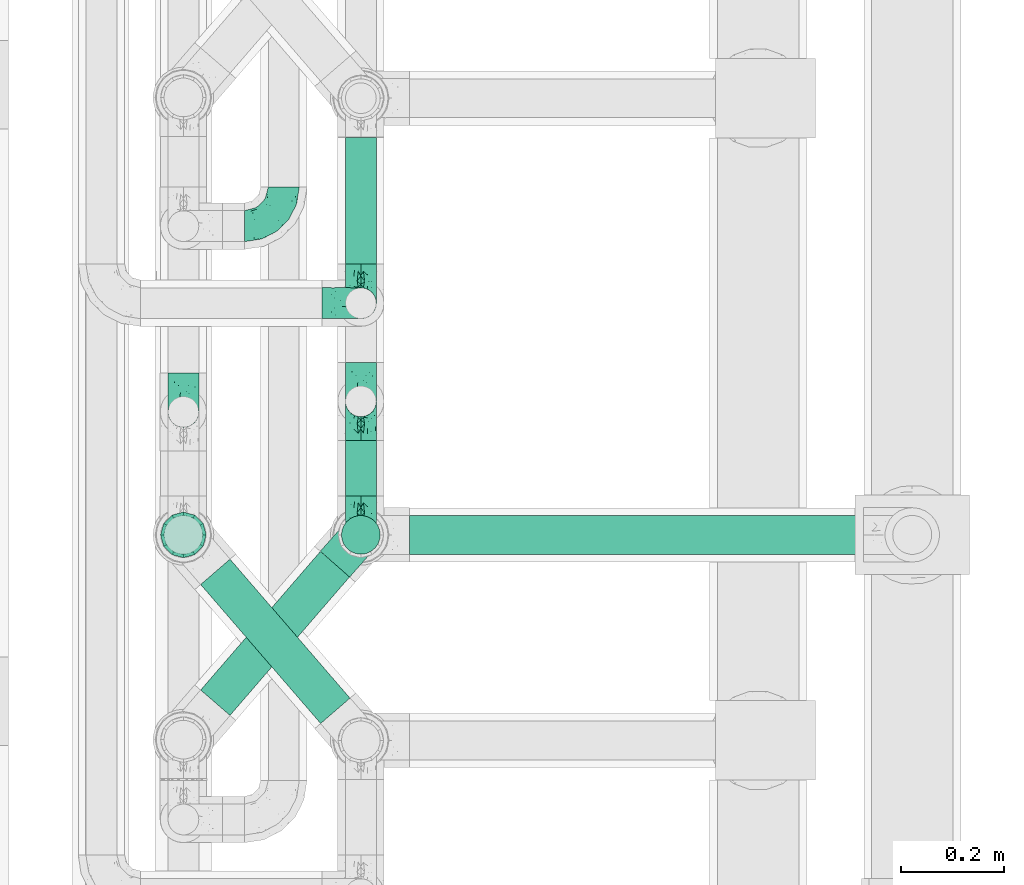
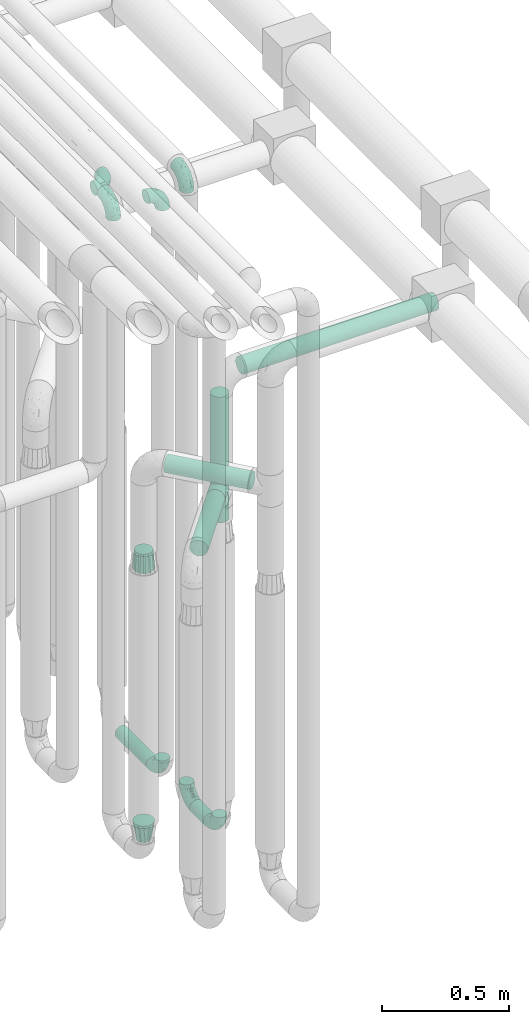
# One storey, part 613 of 827: 10 flow fittings, 7 flow segments.
"""IFC2X3 building model written with IfcOpenShell, lengths in millimetres."""

import ifcopenshell
import ifcopenshell.guid

model = None  # the IFC model being written
_history = None  # IfcOwnerHistory: only IFC2X3 demands one
_inside = {}  # id of a spatial element -> (the spatial element, [elements in it])
_under = {}  # id of a project, library or spatial element -> (it, [spatial elements below it])
_declared = {}  # id of a project -> (the project, [libraries it declares])
_typed = {}  # id of a type object -> (the type object, [elements of that type])
_made_of = {}  # id of a material, layer set ... -> (it, [elements and type objects made of it])


def new_model(schema):
    """Start an empty IFC model of exactly this schema.

    Asked for "IFC4X3", IfcOpenShell would pick the latest addendum, in which some entities
    have other attributes; the version numbers below select the first issue.
    IFC2X3 requires an IfcOwnerHistory on every rooted entity: one is made here for all.
    """
    global model, _history
    if schema == "IFC4X3":
        model = ifcopenshell.file(schema_version=(4, 3, 0, 0))
    else:
        model = ifcopenshell.file(schema=schema)
    _inside.clear()
    _under.clear()
    _declared.clear()
    _typed.clear()
    _made_of.clear()
    _history = None
    if model.schema == "IFC2X3":
        org = make("IfcOrganization", Name="unknown")
        user = make(
            "IfcPersonAndOrganization",
            ThePerson=make("IfcPerson", FamilyName="unknown"),
            TheOrganization=org,
        )
        app = make(
            "IfcApplication",
            ApplicationDeveloper=org,
            Version="unknown",
            ApplicationFullName="unknown",
            ApplicationIdentifier="unknown",
        )
        _history = make(
            "IfcOwnerHistory",
            OwningUser=user,
            OwningApplication=app,
            ChangeAction="ADDED",
            CreationDate=0,
        )
    return model


def make(cls, **values):
    """One entity of the class cls with the attributes given. An attribute that is None is left unset."""
    return model.create_entity(
        cls, **{name: value for name, value in values.items() if value is not None}
    )


def entity(cls, *values):
    """Any entity or typed value of the class cls, its attributes in the order of the schema. None: left unset."""
    e = model.create_entity(cls)
    for i, value in enumerate(values):
        if value is not None:
            e[i] = value
    return e


def rooted(cls, **values):
    """An entity with a GlobalId (a new one), such as an element, a storey or a relation."""
    return make(cls, GlobalId=ifcopenshell.guid.new(), OwnerHistory=_history, **values)


def si_unit(unit_type, name, prefix=None):
    """IfcSIUnit, for example si_unit("LENGTHUNIT", "METRE", prefix="MILLI")."""
    return make("IfcSIUnit", UnitType=unit_type, Prefix=prefix, Name=name)


def converted_unit(unit_type, name, factor, base, dimensions=None, offset=None):
    """IfcConversionBasedUnit, such as the inch: factor (a typed value) times the base unit."""
    return make(
        "IfcConversionBasedUnit"
        if offset is None
        else "IfcConversionBasedUnitWithOffset",
        ConversionOffset=offset,
        Dimensions=None
        if dimensions is None
        else entity("IfcDimensionalExponents", *dimensions),
        UnitType=unit_type,
        Name=name,
        ConversionFactor=make(
            "IfcMeasureWithUnit", ValueComponent=factor, UnitComponent=base
        ),
    )


def derived_unit(unit_type, elements):
    """IfcDerivedUnit: a product of units, each with its exponent."""
    return make(
        "IfcDerivedUnit",
        Elements=[
            make("IfcDerivedUnitElement", Unit=unit, Exponent=power)
            for unit, power in elements
        ],
        UnitType=unit_type,
    )


def assignment(units):
    """IfcUnitAssignment: the units of a project."""
    return None if units is None else make("IfcUnitAssignment", Units=units)


def point(xyz):
    """IfcCartesianPoint."""
    return None if xyz is None else make("IfcCartesianPoint", Coordinates=xyz)


def direction(xyz):
    """IfcDirection."""
    return None if xyz is None else make("IfcDirection", DirectionRatios=xyz)


def frame(location, z_axis=None, x_axis=None):
    """IfcAxis2Placement3D, a coordinate frame: its origin and axes. An axis left out is left unset."""
    return make(
        "IfcAxis2Placement3D",
        Location=point(location),
        Axis=direction(z_axis),
        RefDirection=direction(x_axis),
    )


def frame_2d(location, x_axis=None):
    """IfcAxis2Placement2D, a coordinate frame in the plane: its origin and x axis."""
    return make(
        "IfcAxis2Placement2D", Location=point(location), RefDirection=direction(x_axis)
    )


def origin():
    """The frame at (0, 0, 0) with its axes left unset."""
    return frame((0.0, 0.0, 0.0))


def origin_2d_with_axis():
    """The frame at (0, 0) in the plane with the x axis (1, 0) written out."""
    return frame_2d((0.0, 0.0), x_axis=(1.0, 0.0))


def place(relative_to, where):
    """IfcLocalPlacement: puts the frame where relative to a parent placement (None: the world)."""
    return make(
        "IfcLocalPlacement", PlacementRelTo=relative_to, RelativePlacement=where
    )


def context(
    kind, dimensions, precision=None, world=None, true_north=None, identifier=None
):
    """IfcGeometricRepresentationContext, for example the 3D "Model" context."""
    return make(
        "IfcGeometricRepresentationContext",
        ContextIdentifier=identifier,
        ContextType=kind,
        CoordinateSpaceDimension=dimensions,
        Precision=precision,
        WorldCoordinateSystem=world,
        TrueNorth=true_north,
    )


def subcontext(parent, identifier, kind, view, scale=None):
    """IfcGeometricRepresentationSubContext, for example "Body" below "Model"."""
    return make(
        "IfcGeometricRepresentationSubContext",
        ContextIdentifier=identifier,
        ContextType=kind,
        ParentContext=parent,
        TargetScale=scale,
        TargetView=view,
    )


def project(units=None, contexts=None):
    """IfcProject with its units and contexts."""
    return rooted(
        "IfcProject",
        Name="project",
        RepresentationContexts=contexts,
        UnitsInContext=assignment(units),
    )


def spatial(cls, under=None, at=None, **own):
    """A site, building, storey or space (cls), placed at a placement, below another one or the project."""
    s = rooted(cls, ObjectPlacement=at, **own)
    if under is not None:
        _under.setdefault(under.id(), (under, []))[1].append(s)
    return s


def profile(cls, at=None, kind="AREA", **sizes):
    """A parametric profile (cls). Its sizes go by their IFC names, for example OverallWidth=200.0."""
    return make(cls, ProfileType=kind, Position=at, **sizes)


def circle(**sizes):
    """IfcCircleProfileDef."""
    return profile("IfcCircleProfileDef", **sizes)


def extrude(swept, where, along, depth):
    """IfcExtrudedAreaSolid: the profile swept, set in the frame where, extruded along a direction by depth."""
    return make(
        "IfcExtrudedAreaSolid",
        SweptArea=swept,
        Position=where,
        ExtrudedDirection=direction(along),
        Depth=depth,
    )


def faces_of(points, faces, orient=None, outer=None):
    """IfcFace entities. A face is a list of loops; a loop is a list of indices into points, from 0.

    orient and outer hold one flag for each loop. By default every Orientation is true, the
    first loop of a face is its IfcFaceOuterBound and the others are IfcFaceBound.
    """
    made = []
    for i, loops in enumerate(faces):
        bounds = []
        for j, loop in enumerate(loops):
            is_outer = j == 0 if outer is None else outer[i][j]
            bounds.append(
                make(
                    "IfcFaceOuterBound" if is_outer else "IfcFaceBound",
                    Bound=make("IfcPolyLoop", Polygon=[points[k] for k in loop]),
                    Orientation=True if orient is None else orient[i][j],
                )
            )
        made.append(make("IfcFace", Bounds=bounds))
    return made


def faceted_brep(points, faces, orient=None, outer=None, voids=None):
    """IfcFacetedBrep: a solid bounded by flat faces; with voids (closed shells), ...WithVoids."""
    shared = [point(p) for p in points]
    hull = make("IfcClosedShell", CfsFaces=faces_of(shared, faces, orient, outer))
    if voids is None:
        return make("IfcFacetedBrep", Outer=hull)
    return make(
        "IfcFacetedBrepWithVoids",
        Outer=hull,
        Voids=[
            make(cls, CfsFaces=faces_of(shared, fs, o, b)) for cls, fs, o, b in voids
        ],
    )


def shape(context_of_items, identifier, shape_type, items):
    """IfcShapeRepresentation: the items that make up one representation, for example the "Body"."""
    return make(
        "IfcShapeRepresentation",
        ContextOfItems=context_of_items,
        RepresentationIdentifier=identifier,
        RepresentationType=shape_type,
        Items=items,
    )


def source(mapping_origin, context_of_items, identifier, shape_type, items):
    """IfcRepresentationMap: a shape defined once, which mapped items show again and again."""
    return make(
        "IfcRepresentationMap",
        MappingOrigin=mapping_origin,
        MappedRepresentation=shape(context_of_items, identifier, shape_type, items),
    )


def transform(
    local_origin,
    x_axis=None,
    y_axis=None,
    z_axis=None,
    scale=None,
    scale2=None,
    scale3=None,
    uniform=True,
):
    """IfcCartesianTransformationOperator3D, or its non-uniform kind. x_axis, y_axis, z_axis: its Axis1, 2, 3."""
    if uniform:
        return make(
            "IfcCartesianTransformationOperator3D",
            Axis1=direction(x_axis),
            Axis2=direction(y_axis),
            LocalOrigin=point(local_origin),
            Scale=scale,
            Axis3=direction(z_axis),
        )
    return make(
        "IfcCartesianTransformationOperator3DnonUniform",
        Axis1=direction(x_axis),
        Axis2=direction(y_axis),
        LocalOrigin=point(local_origin),
        Scale=scale,
        Axis3=direction(z_axis),
        Scale2=scale2,
        Scale3=scale3,
    )


def mapped(mapping_source, mapping_target):
    """IfcMappedItem: shows the shape of a source again, moved by a transform."""
    return make(
        "IfcMappedItem", MappingSource=mapping_source, MappingTarget=mapping_target
    )


def material(Name=None, Category=None):
    """IfcMaterial."""
    return make("IfcMaterial", Name=Name, Category=Category)


def made_of(thing, what):
    """Note that an element or type object is made of a material, layer set ...; save() writes the relation."""
    if what is not None:
        _made_of.setdefault(what.id(), (what, []))[1].append(thing)
    return thing


def type_object(cls, material=None, **own):
    """A type object (cls), such as IfcWallType, which elements share."""
    return made_of(rooted(cls, **own), material)


def type_shapes(of_type, sources):
    """Give a type object the sources (RepresentationMaps) that its elements show as mapped items."""
    of_type.RepresentationMaps = sources


def element(
    cls,
    number,
    at=None,
    inside=None,
    cuts=None,
    type_object=None,
    material=None,
    context=None,
    identifier="Body",
    shape_type=None,
    held_by="IfcProductDefinitionShape",
    body=None,
    shapes=None,
    **own,
):
    """One element of the class cls, such as IfcWall. Its Tag is "e" and its number.

    at: its placement. inside: the storey or other place that contains it. cuts: it is an
    opening in that element (IfcRelVoidsElement). A single representation is given by context,
    identifier, shape_type and body (its items); several are given by shapes. held_by: the class
    of the entity that holds the representations. save() writes the other relations.
    """
    e = rooted(cls, Tag="e%d" % number, ObjectPlacement=at, **own)
    if body is not None:
        shapes = [shape(context, identifier, shape_type, body)]
    if shapes is not None:
        e.Representation = make(held_by, Representations=shapes)
    if inside is not None:
        _inside.setdefault(inside.id(), (inside, []))[1].append(e)
    if cuts is not None:
        rooted(
            "IfcRelVoidsElement", RelatingBuildingElement=cuts, RelatedOpeningElement=e
        )
    if type_object is not None:
        _typed.setdefault(type_object.id(), (type_object, []))[1].append(e)
    return made_of(e, material)


def aggregate(whole, parts):
    """IfcRelAggregates: a whole, such as a stair, and the parts it consists of."""
    return rooted("IfcRelAggregates", RelatingObject=whole, RelatedObjects=parts)


def save(model, path):
    """Write the relations noted so far, then the file.

    IfcRelAggregates (storeys below a building ...), IfcRelContainedInSpatialStructure (elements
    in a storey), IfcRelDefinesByType, IfcRelAssociatesMaterial and IfcRelDeclares: one each for
    every whole, place, type object, material and project.
    """
    for whole, parts in _under.values():
        aggregate(whole, parts)
    for where, things in _inside.values():
        rooted(
            "IfcRelContainedInSpatialStructure",
            RelatedElements=things,
            RelatingStructure=where,
        )
    for kind, things in _typed.values():
        rooted("IfcRelDefinesByType", RelatedObjects=things, RelatingType=kind)
    for what, things in _made_of.values():
        rooted("IfcRelAssociatesMaterial", RelatedObjects=things, RelatingMaterial=what)
    for by, libraries in _declared.values():
        rooted("IfcRelDeclares", RelatingContext=by, RelatedDefinitions=libraries)
    model.write(path)


model = new_model("IFC2X3")

# Units and contexts
model_context = context("Model", 3, precision=0.01, world=origin(), true_north=direction((6.12303176911189e-17, 1.0)))
body_context = subcontext(model_context, "Body", "Model", "MODEL_VIEW")
ifc_project = project(units=[si_unit("LENGTHUNIT", "METRE", prefix="MILLI"), si_unit("AREAUNIT", "SQUARE_METRE"), si_unit("VOLUMEUNIT", "CUBIC_METRE"), converted_unit("PLANEANGLEUNIT", "DEGREE", entity("IfcRatioMeasure", 0.0174532925199433), si_unit("PLANEANGLEUNIT", "RADIAN"), dimensions=[0, 0, 0, 0, 0, 0, 0]), si_unit("MASSUNIT", "GRAM", prefix="KILO"), derived_unit("MASSDENSITYUNIT", [(si_unit("MASSUNIT", "GRAM", prefix="KILO"), 1), (si_unit("LENGTHUNIT", "METRE"), -3)]), derived_unit("MOMENTOFINERTIAUNIT", [(si_unit("LENGTHUNIT", "METRE"), 4)]), si_unit("TIMEUNIT", "SECOND"), si_unit("FREQUENCYUNIT", "HERTZ"), si_unit("THERMODYNAMICTEMPERATUREUNIT", "DEGREE_CELSIUS"), derived_unit("THERMALTRANSMITTANCEUNIT", [(si_unit("MASSUNIT", "GRAM", prefix="KILO"), 1), (si_unit("THERMODYNAMICTEMPERATUREUNIT", "KELVIN"), -1), (si_unit("TIMEUNIT", "SECOND"), -3)]), derived_unit("VOLUMETRICFLOWRATEUNIT", [(si_unit("LENGTHUNIT", "METRE"), 3), (si_unit("TIMEUNIT", "SECOND"), -1)]), derived_unit("MASSFLOWRATEUNIT", [(si_unit("MASSUNIT", "GRAM", prefix="KILO"), 1), (si_unit("TIMEUNIT", "SECOND"), -1)]), derived_unit("ROTATIONALFREQUENCYUNIT", [(si_unit("TIMEUNIT", "SECOND"), -1)]), si_unit("ELECTRICCURRENTUNIT", "AMPERE"), si_unit("ELECTRICVOLTAGEUNIT", "VOLT"), si_unit("POWERUNIT", "WATT"), si_unit("FORCEUNIT", "NEWTON", prefix="KILO"), si_unit("ILLUMINANCEUNIT", "LUX"), si_unit("LUMINOUSFLUXUNIT", "LUMEN"), si_unit("LUMINOUSINTENSITYUNIT", "CANDELA"), derived_unit("USERDEFINED", [(si_unit("MASSUNIT", "GRAM", prefix="KILO"), -1), (si_unit("LENGTHUNIT", "METRE"), -2), (si_unit("TIMEUNIT", "SECOND"), 3), (si_unit("LUMINOUSFLUXUNIT", "LUMEN"), 1)]), derived_unit("LINEARVELOCITYUNIT", [(si_unit("LENGTHUNIT", "METRE"), 1), (si_unit("TIMEUNIT", "SECOND"), -1)]), si_unit("PRESSUREUNIT", "PASCAL"), derived_unit("USERDEFINED", [(si_unit("LENGTHUNIT", "METRE"), -2), (si_unit("MASSUNIT", "GRAM", prefix="KILO"), 1), (si_unit("TIMEUNIT", "SECOND"), -2)]), derived_unit("LINEARFORCEUNIT", [(si_unit("MASSUNIT", "GRAM", prefix="KILO"), 1), (si_unit("LENGTHUNIT", "METRE"), 1), (si_unit("TIMEUNIT", "SECOND"), -2), (si_unit("LENGTHUNIT", "METRE"), -1)]), derived_unit("PLANARFORCEUNIT", [(si_unit("MASSUNIT", "GRAM", prefix="KILO"), 1), (si_unit("LENGTHUNIT", "METRE"), 1), (si_unit("TIMEUNIT", "SECOND"), -2), (si_unit("LENGTHUNIT", "METRE"), -2)])], contexts=[model_context])

# Site, building, storey
site_placement = place(None, origin())
site = spatial("IfcSite", under=ifc_project, at=site_placement, CompositionType="ELEMENT")
building_placement = place(site_placement, origin())
building = spatial("IfcBuilding", under=site, at=building_placement, CompositionType="ELEMENT")
storey_placement = place(building_placement, frame((0.0, 0.0, 28200.0)))
storey = spatial("IfcBuildingStorey", under=building, at=storey_placement, Name="08", CompositionType="ELEMENT", Elevation=28200.0)

# Flow segments
pipe_segment_type = type_object("IfcPipeSegmentType", PredefinedType="NOTDEFINED")
flow_segment_1_placement = place(storey_placement, frame((36943.44, 11007.17, 368.4)))
element("IfcFlowSegment", 1, at=flow_segment_1_placement, inside=storey, type_object=pipe_segment_type, context=body_context, shape_type="SweptSolid", body=[
    extrude(circle(Radius=30.0, at=origin_2d_with_axis()), frame((31.6, 0.0, 31.6), z_axis=(0.0, 1.0, 0.0), x_axis=(1.0, 0.0, 0.0)), (0.0, 0.0, 1.0), 247.028730184572),
])
flow_segment_2_placement = place(storey_placement, frame((36943.44, 10556.2, 368.4)))
element("IfcFlowSegment", 2, at=flow_segment_2_placement, inside=storey, type_object=pipe_segment_type, context=body_context, shape_type="SweptSolid", body=[
    extrude(circle(Radius=30.0, at=origin_2d_with_axis()), frame((31.6, 0.0, 31.6), z_axis=(0.0, 1.0, 0.0), x_axis=(-1.0, 0.0, 0.0)), (0.0, 0.0, 1.0), 108.000000000017),
])
flow_segment_3_placement = place(storey_placement, frame((36935.69, 10440.86, 2126.0)))
element("IfcFlowSegment", 3, at=flow_segment_3_placement, inside=storey, type_object=pipe_segment_type, context=body_context, shape_type="SweptSolid", body=[
    extrude(circle(Radius=37.75, at=origin_2d_with_axis()), frame((39.35, 39.35, 0.0), z_axis=(0.0, 0.0, 1.0), x_axis=(-1.0, 0.0, 0.0)), (0.0, 0.0, 1.0), 378.999999999996),
])
flow_segment_4_placement = place(storey_placement, frame((37070.03, 10440.86, 2560.65)))
element("IfcFlowSegment", 4, at=flow_segment_4_placement, inside=storey, type_object=pipe_segment_type, context=body_context, shape_type="SweptSolid", body=[
    extrude(circle(Radius=37.75, at=origin_2d_with_axis()), frame((0.0, 39.35, 39.35), z_axis=(1.0, 0.0, 0.0), x_axis=(0.0, -1.0, 0.0)), (0.0, 0.0, 1.0), 883.26568841584),
])
flow_segment_5_placement = place(storey_placement, frame((36661.57, 10111.47, 2265.65)))
element("IfcFlowSegment", 5, at=flow_segment_5_placement, inside=storey, type_object=pipe_segment_type, context=body_context, shape_type="SweptSolid", body=[
    extrude(circle(Radius=37.75, at=origin_2d_with_axis()), frame((30.17, 296.83, 39.35), z_axis=(0.65359148401651, -0.756847522306242, 0.0), x_axis=(-0.756847522306242, -0.65359148401651, 0.0)), (0.0, 0.0, 1.0), 357.482862990724),
])
flow_segment_6_placement = place(storey_placement, frame((36661.57, 10127.22, 2010.65)))
element("IfcFlowSegment", 6, at=flow_segment_6_placement, inside=storey, type_object=pipe_segment_type, context=body_context, shape_type="SweptSolid", body=[
    extrude(circle(Radius=37.75, at=origin_2d_with_axis()), frame((30.17, 26.27, 39.35), z_axis=(0.653617255256319, 0.756825266247894, 0.0), x_axis=(0.756825266247894, -0.653617255256319, 0.0)), (0.0, 0.0, 1.0), 356.436515701913),
])
flow_segment_7_placement = place(storey_placement, frame((36935.69, 10440.86, 1900.0)))
element("IfcFlowSegment", 7, at=flow_segment_7_placement, inside=storey, type_object=pipe_segment_type, context=body_context, shape_type="SweptSolid", body=[
    extrude(circle(Radius=37.75, at=origin_2d_with_axis()), frame((39.35, 39.35, 0.0), z_axis=(0.0, 0.0, 1.0), x_axis=(-1.0, 0.0, 0.0)), (0.0, 0.0, 1.0), 74.0000000000048),
])

# Flow fittings
ifc_material = material()
pipe_fitting_type_1 = type_object("IfcPipeFittingType", Name="ADSK_1", PredefinedType="NOTDEFINED", material=ifc_material)
shared_shape_1 = source(origin(), body_context, "Body", "Brep", [
    faceted_brep([(-76.0, 15.07, -26.11), (-76.0, 7.8, -29.12), (-76.0, 0.0, -30.15), (-76.0, -7.8, -29.12), (-76.0, -15.08, -26.11), (-76.0, -21.32, -21.32), (-76.0, -26.11, -15.08), (-76.0, -29.12, -7.8), (-76.0, -30.15, 0.0), (-76.0, -29.12, 7.8), (-76.0, -26.11, 15.07), (-76.0, -21.32, 21.32), (-76.0, -15.08, 26.11), (-76.0, -7.8, 29.12), (-76.0, 0.0, 30.15), (-76.0, 7.8, 29.12), (-76.0, 15.07, 26.11), (-76.0, 21.32, 21.32), (-76.0, 26.11, 15.07), (-76.0, 29.12, 7.8), (-76.0, 30.15, 0.0), (-76.0, 29.12, -7.8), (-76.0, 26.11, -15.08), (-76.0, 21.32, -21.32), (0.0, 76.0, -30.15), (-7.8, 76.0, -29.12), (-15.07, 76.0, -26.11), (-21.32, 76.0, -21.32), (-26.11, 76.0, -15.08), (-29.12, 76.0, -7.8), (-30.15, 76.0, 0.0), (-29.12, 76.0, 7.8), (-26.11, 76.0, 15.07), (-21.32, 76.0, 21.32), (-15.07, 76.0, 26.11), (-7.8, 76.0, 29.12), (0.0, 76.0, 30.15), (7.8, 76.0, 29.12), (15.08, 76.0, 26.11), (21.32, 76.0, 21.32), (26.11, 76.0, 15.07), (29.12, 76.0, 7.8), (30.15, 76.0, 0.0), (29.12, 76.0, -7.8), (26.11, 76.0, -15.08), (21.32, 76.0, -21.32), (15.08, 76.0, -26.11), (7.8, 76.0, -29.12), (10.79, 31.43, 21.07), (4.32, 31.7, 25.72), (1.65, 15.19, 19.92), (-61.17, -27.8, 0.0), (-51.1, -25.49, 9.84), (-56.14, -10.61, 27.27), (-31.7, -4.32, 25.72), (-39.75, 1.72, 29.41), (-43.2, -24.95, 0.0), (-1.86, 1.86, 0.0), (4.49, 7.65, 5.78), (-7.82, -4.61, 5.83), (-56.21, -22.79, 17.21), (-58.98, -3.38, 29.7), (-53.96, 5.6, 30.07), (-10.86, 10.86, 25.48), (-17.2, -2.6, 20.44), (-49.15, -16.01, 22.7), (-22.18, -14.24, 7.99), (-28.4, -17.42, 0.0), (-13.61, -9.88, 0.0), (-39.0, 23.48, 27.76), (-58.76, 12.54, 28.36), (-41.61, 15.41, 29.48), (16.01, 49.15, 22.7), (-58.55, 25.93, 19.53), (-51.53, 33.5, 13.51), (-64.92, 28.76, 12.4), (-7.48, 23.14, 28.25), (-1.72, 39.75, 29.41), (-12.04, 27.88, 29.88), (-63.91, 18.81, 24.52), (-11.63, 65.16, 28.18), (-4.97, 57.02, 30.05), (9.88, 13.61, 0.0), (-62.5, 31.74, 5.02), (-45.17, 30.98, 21.2), (-21.78, 9.76, 28.58), (10.61, 56.14, 27.27), (-32.09, 54.42, 13.26), (22.79, 56.21, 17.21), (15.38, 31.17, 15.63), (25.49, 51.1, 9.84), (21.84, 36.35, 5.92), (24.95, 43.2, 0.0), (3.38, 58.98, 29.7), (-31.17, -15.38, 15.63), (-39.39, 41.78, 15.45), (-34.56, 41.13, 20.79), (-39.81, -23.25, 5.49), (27.8, 61.17, 0.0), (-31.74, 62.5, 5.02), (-53.07, 36.29, 0.0), (-42.95, 42.95, 7.29), (-36.29, 53.07, 0.0), (-19.83, 58.51, 24.79), (-25.48, 60.2, 19.41), (-14.53, 50.96, 28.57), (-13.31, 37.09, 30.07), (-26.16, 40.06, 26.4), (-32.43, -10.35, 21.9), (17.42, 28.4, 0.0), (14.24, 22.18, 7.99), (-38.67, 9.72, 30.15), (-24.66, 17.36, 30.09), (-37.08, 31.49, 24.99), (-49.27, 22.83, 25.24), (-20.8, 38.81, 28.63), (-27.58, 27.58, 29.2), (-36.07, -20.23, 10.71), (-15.19, -6.16, 14.9), (6.6, 15.4, 14.49), (-2.51, 2.51, 11.35), (-65.16, 11.63, -28.18), (-49.15, -16.01, -22.7), (-57.02, 4.97, -30.05), (-25.93, 58.55, -19.53), (-33.5, 51.53, -13.51), (-28.76, 64.92, -12.4), (-60.2, 25.48, -19.41), (-58.51, 19.83, -24.79), (4.61, 7.82, -5.83), (-7.65, -4.49, -5.78), (-2.51, 2.51, -11.35), (-62.5, 31.74, -5.02), (-50.96, 14.53, -28.57), (-37.09, 13.31, -30.07), (-42.95, 42.95, -7.29), (25.49, 51.1, -9.84), (22.79, 56.21, -17.21), (-40.06, 26.16, -26.4), (3.38, 58.98, -29.7), (-5.6, 53.96, -30.07), (-27.88, 12.04, -29.88), (-9.76, 21.78, -28.58), (-23.14, 7.48, -28.25), (-51.1, -25.49, -9.84), (15.38, 31.17, -15.63), (16.01, 49.15, -22.7), (-23.48, 39.0, -27.76), (-12.54, 58.76, -28.36), (-15.41, 41.61, -29.48), (-56.21, -22.79, -17.21), (-9.72, 38.67, -30.15), (-17.36, 24.66, -30.09), (-22.18, -14.24, -7.99), (-41.13, 34.56, -20.79), (-31.74, 62.5, -5.02), (-58.98, -3.38, -29.7), (-31.17, -15.38, -15.63), (-56.14, -10.61, -27.27), (14.24, 22.18, -7.99), (23.25, 39.81, -5.49), (-31.49, 37.08, -24.99), (-15.19, -6.16, -14.9), (1.65, 15.19, -19.92), (-18.81, 63.91, -24.52), (-32.59, -11.62, -20.84), (-31.7, -4.32, -25.72), (-17.2, -2.6, -20.44), (-39.75, 1.72, -29.41), (-54.42, 32.09, -13.26), (-30.98, 45.17, -21.2), (10.61, 56.14, -27.27), (10.23, 31.31, -21.52), (4.32, 31.7, -25.72), (-41.78, 39.39, -15.45), (-1.72, 39.75, -29.41), (-36.35, -21.84, -5.92), (-22.83, 49.27, -25.24), (-38.81, 20.8, -28.63), (-27.58, 27.58, -29.2), (-10.86, 10.86, -25.48), (20.23, 36.07, -10.71), (6.6, 15.4, -14.49)], [[[0, 1, 2, 3, 4, 5, 6, 7, 8, 9, 10, 11, 12, 13, 14, 15, 16, 17, 18, 19, 20, 21, 22, 23]], [[24, 25, 26, 27, 28, 29, 30, 31, 32, 33, 34, 35, 36, 37, 38, 39, 40, 41, 42, 43, 44, 45, 46, 47]], [[48, 49, 50]], [[51, 52, 9]], [[53, 54, 55]], [[9, 52, 10]], [[56, 52, 51]], [[57, 58, 59]], [[11, 10, 60]], [[14, 61, 62]], [[63, 54, 64]], [[65, 12, 11]], [[65, 53, 12]], [[66, 67, 68]], [[69, 70, 71]], [[72, 39, 38]], [[73, 74, 75]], [[15, 70, 16]], [[76, 77, 78]], [[16, 79, 17]], [[13, 61, 14]], [[35, 80, 81]], [[14, 62, 15]], [[17, 73, 18]], [[57, 82, 58]], [[20, 19, 83]], [[75, 19, 18]], [[70, 15, 62]], [[73, 84, 74]], [[78, 85, 76]], [[38, 86, 72]], [[32, 31, 87]], [[88, 89, 90]], [[91, 92, 90]], [[72, 86, 49]], [[36, 93, 37]], [[75, 83, 19]], [[36, 35, 81]], [[60, 94, 65]], [[40, 90, 41]], [[95, 96, 87]], [[88, 90, 40]], [[66, 97, 67]], [[90, 98, 41]], [[40, 39, 88]], [[99, 31, 30]], [[20, 83, 100]], [[101, 102, 100]], [[52, 60, 10]], [[102, 99, 30]], [[96, 103, 104]], [[83, 101, 100]], [[12, 53, 13]], [[104, 103, 33]], [[105, 106, 81]], [[107, 105, 103]], [[64, 54, 108]], [[80, 103, 105]], [[80, 35, 34]], [[34, 33, 103]], [[86, 38, 37]], [[109, 110, 82]], [[71, 111, 112]], [[69, 107, 113]], [[79, 73, 17]], [[114, 113, 84]], [[33, 32, 104]], [[115, 107, 116]], [[105, 115, 106]], [[93, 81, 77]], [[54, 53, 65]], [[61, 53, 55]], [[108, 94, 64]], [[54, 63, 85]], [[93, 86, 37]], [[77, 76, 49]], [[77, 49, 86]], [[49, 63, 50]], [[60, 52, 117]], [[65, 11, 60]], [[39, 72, 88]], [[89, 88, 72]], [[71, 70, 62]], [[79, 70, 114]], [[103, 96, 107]], [[69, 113, 114]], [[112, 106, 116]], [[77, 81, 106]], [[112, 116, 71]], [[112, 55, 85]], [[64, 50, 63]], [[57, 59, 68]], [[32, 87, 104]], [[96, 104, 87]], [[94, 118, 64]], [[50, 119, 89]], [[50, 64, 118]], [[50, 89, 48]], [[81, 93, 36]], [[86, 93, 77]], [[53, 61, 13]], [[62, 61, 55]], [[71, 62, 111]], [[69, 71, 116]], [[95, 101, 74]], [[99, 101, 87]], [[118, 66, 59]], [[117, 97, 66]], [[117, 66, 94]], [[91, 89, 110]], [[91, 110, 109]], [[110, 89, 119]], [[9, 8, 51]], [[98, 90, 92]], [[98, 42, 41]], [[101, 83, 74]], [[101, 99, 102]], [[87, 31, 99]], [[62, 55, 111]], [[55, 112, 111]], [[107, 69, 116]], [[70, 69, 114]], [[107, 96, 113]], [[84, 113, 96]], [[84, 96, 95]], [[114, 84, 73]], [[70, 79, 16]], [[73, 79, 114]], [[54, 85, 55]], [[76, 85, 63]], [[49, 76, 63]], [[77, 106, 78]], [[106, 112, 78]], [[85, 78, 112]], [[73, 75, 18]], [[83, 75, 74]], [[103, 80, 34]], [[81, 80, 105]], [[101, 95, 87]], [[84, 95, 74]], [[106, 115, 116]], [[105, 107, 115]], [[120, 59, 58]], [[82, 110, 58]], [[119, 58, 110]], [[118, 59, 120]], [[66, 68, 59]], [[54, 65, 108]], [[94, 108, 65]], [[66, 118, 94]], [[50, 118, 120]], [[50, 120, 119]], [[119, 120, 58]], [[89, 72, 48]], [[49, 48, 72]], [[60, 117, 94]], [[117, 52, 97]], [[52, 56, 97]], [[67, 97, 56]], [[92, 91, 109]], [[89, 91, 90]], [[121, 1, 0]], [[122, 5, 4]], [[2, 1, 123]], [[124, 125, 126]], [[127, 128, 23]], [[129, 130, 131]], [[100, 132, 20]], [[133, 134, 123]], [[135, 100, 102]], [[136, 137, 44]], [[133, 128, 138]], [[24, 139, 140]], [[141, 142, 143]], [[121, 128, 133]], [[6, 144, 7]], [[137, 145, 146]], [[144, 51, 7]], [[147, 148, 149]], [[144, 6, 150]], [[149, 151, 152]], [[153, 68, 67]], [[154, 128, 127]], [[30, 155, 102]], [[43, 42, 98]], [[156, 3, 2]], [[157, 144, 150]], [[158, 4, 3]], [[24, 140, 25]], [[155, 135, 102]], [[159, 160, 109]], [[30, 29, 155]], [[147, 138, 161]], [[27, 124, 28]], [[57, 129, 82]], [[162, 163, 131]], [[27, 26, 164]], [[148, 26, 25]], [[165, 166, 167]], [[24, 47, 139]], [[143, 168, 141]], [[22, 21, 169]], [[125, 124, 170]], [[148, 25, 140]], [[46, 146, 171]], [[158, 122, 4]], [[0, 23, 128]], [[1, 121, 123]], [[109, 82, 159]], [[45, 44, 137]], [[146, 46, 45]], [[136, 43, 98]], [[132, 21, 20]], [[136, 98, 92]], [[172, 173, 146]], [[46, 171, 47]], [[43, 136, 44]], [[174, 154, 169]], [[171, 173, 175]], [[6, 5, 150]], [[126, 29, 28]], [[176, 56, 144]], [[122, 158, 166]], [[164, 124, 27]], [[177, 161, 170]], [[23, 22, 127]], [[178, 138, 179]], [[133, 178, 134]], [[156, 123, 168]], [[156, 158, 3]], [[168, 143, 166]], [[168, 166, 158]], [[166, 180, 167]], [[173, 171, 146]], [[139, 171, 175]], [[172, 145, 163]], [[173, 180, 142]], [[5, 122, 150]], [[157, 150, 122]], [[137, 136, 181]], [[146, 45, 137]], [[149, 148, 140]], [[164, 148, 177]], [[128, 154, 138]], [[147, 161, 177]], [[152, 134, 179]], [[168, 123, 134]], [[152, 179, 149]], [[152, 175, 142]], [[57, 130, 129]], [[157, 165, 167]], [[22, 169, 127]], [[154, 127, 169]], [[163, 167, 180]], [[162, 157, 167]], [[173, 163, 180]], [[182, 163, 145]], [[123, 156, 2]], [[158, 156, 168]], [[171, 139, 47]], [[140, 139, 175]], [[149, 140, 151]], [[147, 149, 179]], [[174, 135, 125]], [[132, 135, 169]], [[176, 157, 153]], [[176, 153, 67]], [[153, 157, 162]], [[182, 159, 129]], [[181, 160, 159]], [[181, 159, 145]], [[51, 144, 56]], [[51, 8, 7]], [[135, 132, 100]], [[169, 21, 132]], [[126, 155, 29]], [[135, 155, 125]], [[140, 175, 151]], [[175, 152, 151]], [[138, 147, 179]], [[148, 147, 177]], [[138, 154, 161]], [[170, 161, 154]], [[170, 154, 174]], [[177, 170, 124]], [[148, 164, 26]], [[124, 164, 177]], [[173, 142, 175]], [[143, 142, 180]], [[166, 143, 180]], [[168, 134, 141]], [[134, 152, 141]], [[142, 141, 152]], [[124, 126, 28]], [[155, 126, 125]], [[128, 121, 0]], [[123, 121, 133]], [[135, 174, 169]], [[170, 174, 125]], [[134, 178, 179]], [[133, 138, 178]], [[130, 153, 162]], [[68, 153, 130]], [[57, 68, 130]], [[182, 129, 131]], [[159, 82, 129]], [[157, 122, 165]], [[166, 165, 122]], [[163, 162, 167]], [[162, 131, 130]], [[145, 172, 146]], [[163, 173, 172]], [[159, 182, 145]], [[131, 163, 182]], [[56, 176, 67]], [[157, 176, 144]], [[137, 181, 145]], [[181, 136, 160]], [[136, 92, 160]], [[109, 160, 92]]]),
])
type_shapes(pipe_fitting_type_1, [shared_shape_1])
flow_fitting_1_placement = place(storey_placement, frame((36825.03, 11081.17, 3200.0)))
element("IfcFlowFitting", 8, at=flow_fitting_1_placement, inside=storey, type_object=pipe_fitting_type_1, material=ifc_material, Name="ADSK_1", ObjectType="ADSK_1", context=body_context, shape_type="MappedRepresentation", body=[
    mapped(shared_shape_1, transform((0.0, 0.0, 0.0), scale=1.0)),
])
for number, where, z_axis, x_axis, name in (
    (9, (36975.03, 10931.17, 400.0), (-1.0, 0.0, 0.0), (0.0, -1.0, 0.0), "ADSK_1"),
    (10, (36975.03, 10931.17, 3200.0), (0.0, -1.0, 0.0), (0.0, 0.0, 1.0), "ADSK_1"),
    (11, (36975.03, 10480.2, 400.0), (-1.0, 0.0, 0.0), (0.0, -1.0, 0.0), "ADSK_1"),
    (12, (36975.03, 10740.2, 400.0), (1.0, 0.0, 0.0), (0.0, 1.0, 0.0), "ADSK_1"),
    (13, (36975.03, 10740.2, 3400.0), (-1.0, 0.0, 0.0), (0.0, 0.0, 1.0), "ADSK_1"),
    (14, (36629.64, 10719.72, 3400.0), (-1.0, 0.0, 0.0), (0.0, 0.0, 1.0), "ADSK_1"),
):
    element("IfcFlowFitting", number, at=place(storey_placement, frame(where, z_axis=z_axis, x_axis=x_axis)), inside=storey, type_object=pipe_fitting_type_1, material=ifc_material, Name=name, ObjectType="ADSK_1", context=body_context, shape_type="MappedRepresentation", body=[
        mapped(shared_shape_1, transform((0.0, 0.0, 0.0), scale=1.0)),
    ])
pipe_fitting_type_2 = type_object("IfcPipeFittingType", Name="ADSK_1", PredefinedType="NOTDEFINED", material=ifc_material)
shared_shape_2 = source(origin(), body_context, "Body", "Brep", [
    faceted_brep([(-76.0, 9.85, -36.75), (-76.0, 0.0, -38.05), (-76.0, -9.85, -36.75), (-76.0, -19.03, -32.95), (-76.0, -22.97, -29.93), (-76.0, -26.91, -26.91), (-76.0, -29.93, -22.97), (-76.0, -32.95, -19.03), (-76.0, -34.85, -14.44), (-76.0, -36.75, -9.85), (-76.0, -38.05, 0.0), (-76.0, -36.75, 9.85), (-76.0, -34.85, 14.44), (-76.0, -32.95, 19.02), (-76.0, -29.93, 22.97), (-76.0, -26.91, 26.91), (-76.0, -22.97, 29.93), (-76.0, -19.03, 32.95), (-76.0, -9.85, 36.75), (-76.0, 0.0, 38.05), (-76.0, 9.85, 36.75), (-76.0, 19.02, 32.95), (-76.0, 26.91, 26.91), (-76.0, 32.95, 19.02), (-76.0, 36.75, 9.85), (-76.0, 38.05, 0.0), (-76.0, 36.75, -9.85), (-76.0, 32.95, -19.03), (-76.0, 26.91, -26.91), (-76.0, 19.02, -32.95), (76.0, 26.91, -26.91), (76.0, 32.95, -19.03), (76.0, 36.75, -9.85), (76.0, 38.05, 0.0), (76.0, 36.75, 9.85), (76.0, 32.95, 19.02), (76.0, 26.91, 26.91), (76.0, 19.02, 32.95), (76.0, 9.85, 36.75), (76.0, 0.0, 38.05), (76.0, -9.85, 36.75), (76.0, -19.03, 32.95), (76.0, -22.97, 29.93), (76.0, -26.91, 26.91), (76.0, -29.93, 22.97), (76.0, -32.95, 19.02), (76.0, -34.85, 14.44), (76.0, -36.75, 9.85), (76.0, -38.05, 0.0), (76.0, -36.75, -9.85), (76.0, -34.85, -14.44), (76.0, -32.95, -19.03), (76.0, -29.93, -22.97), (76.0, -26.91, -26.91), (76.0, -22.97, -29.93), (76.0, -19.03, -32.95), (76.0, -9.85, -36.75), (76.0, 0.0, -38.05), (76.0, 9.85, -36.75), (76.0, 19.02, -32.95), (36.99, -36.99, 8.94), (38.05, -38.05, 0.0), (-36.99, -36.99, 8.94), (-38.05, -38.05, 0.0), (35.51, -35.51, 12.97), (34.04, -34.04, 17.0), (18.81, -18.81, 33.08), (29.74, -29.74, 23.73), (24.56, -24.56, 29.06), (-35.51, -35.51, 12.97), (-34.04, -34.04, 17.0), (-18.81, -18.81, 33.08), (-29.74, -29.74, 23.73), (-24.56, -24.56, 29.06), (-12.7, -12.7, 35.87), (6.4, -6.4, 37.51), (12.7, -12.7, 35.87), (0.0, 0.0, 38.05), (-6.4, -6.4, 37.51), (6.4, -6.4, -37.51), (0.0, 0.0, -38.05), (12.7, -12.7, -35.87), (-24.56, -24.56, -29.06), (-6.4, -6.4, -37.51), (-35.51, -35.51, -12.97), (-36.99, -36.99, -8.94), (-29.74, -29.74, -23.73), (-12.7, -12.7, -35.87), (18.81, -18.81, -33.08), (24.56, -24.56, -29.06), (-34.04, -34.04, -17.0), (29.74, -29.74, -23.73), (36.99, -36.99, -8.94), (35.51, -35.51, -12.97), (34.04, -34.04, -17.0), (-18.81, -18.81, -33.08), (9.85, -76.0, -36.75), (19.03, -76.0, -32.95), (26.91, -76.0, -26.91), (32.95, -76.0, -19.03), (36.75, -76.0, -9.85), (38.05, -76.0, 0.0), (36.75, -76.0, 9.85), (32.95, -76.0, 19.02), (26.91, -76.0, 26.91), (19.03, -76.0, 32.95), (9.85, -76.0, 36.75), (0.0, -76.0, 38.05), (-9.85, -76.0, 36.75), (-19.02, -76.0, 32.95), (-26.91, -76.0, 26.91), (-32.95, -76.0, 19.02), (-36.75, -76.0, 9.85), (-38.05, -76.0, 0.0), (-36.75, -76.0, -9.85), (-32.95, -76.0, -19.03), (-26.91, -76.0, -26.91), (-19.02, -76.0, -32.95), (-9.85, -76.0, -36.75), (0.0, -76.0, -38.05)], [[[0, 1, 2, 3, 4, 5, 6, 7, 8, 9, 10, 11, 12, 13, 14, 15, 16, 17, 18, 19, 20, 21, 22, 23, 24, 25, 26, 27, 28, 29]], [[30, 31, 32, 33, 34, 35, 36, 37, 38, 39, 40, 41, 42, 43, 44, 45, 46, 47, 48, 49, 50, 51, 52, 53, 54, 55, 56, 57, 58, 59]], [[48, 47, 60]], [[60, 61, 48]], [[62, 10, 63]], [[47, 46, 64]], [[46, 45, 65]], [[41, 66, 42]], [[43, 67, 45, 44]], [[67, 43, 68]], [[45, 67, 65]], [[68, 43, 42]], [[11, 69, 12]], [[70, 12, 69]], [[10, 62, 11]], [[11, 62, 69]], [[71, 17, 16]], [[72, 73, 15]], [[72, 15, 14, 13]], [[15, 73, 16]], [[71, 74, 17]], [[72, 13, 70]], [[46, 65, 64]], [[42, 66, 68]], [[40, 39, 75]], [[47, 64, 60]], [[66, 41, 76]], [[75, 76, 40]], [[75, 39, 77]], [[78, 77, 19]], [[76, 41, 40]], [[23, 22, 36, 35]], [[24, 23, 35, 34]], [[21, 20, 38, 37]], [[22, 21, 37, 36]], [[38, 20, 19, 77, 39]], [[25, 24, 34, 33]], [[70, 13, 12]], [[78, 18, 74]], [[18, 78, 19]], [[18, 17, 74]], [[71, 16, 73]], [[28, 27, 31, 30]], [[26, 32, 31, 27]], [[25, 33, 32, 26]], [[29, 28, 30, 59]], [[57, 56, 79]], [[58, 57, 80, 1, 0]], [[79, 56, 81]], [[82, 5, 4]], [[59, 58, 0, 29]], [[56, 55, 81]], [[57, 79, 80]], [[80, 83, 1]], [[9, 84, 85]], [[86, 7, 6, 5]], [[83, 87, 2]], [[1, 83, 2]], [[87, 3, 2]], [[88, 54, 89]], [[54, 53, 89]], [[8, 90, 84]], [[88, 55, 54]], [[91, 89, 53]], [[52, 51, 91, 53]], [[55, 88, 81]], [[49, 92, 93]], [[92, 49, 48]], [[94, 50, 93]], [[61, 92, 48]], [[85, 63, 10]], [[51, 94, 91]], [[82, 4, 95]], [[49, 93, 50]], [[4, 3, 95]], [[5, 82, 86]], [[94, 51, 50]], [[95, 3, 87]], [[9, 8, 84]], [[90, 8, 7]], [[9, 85, 10]], [[90, 7, 86]], [[96, 97, 98, 99, 100, 101, 102, 103, 104, 105, 106, 107, 108, 109, 110, 111, 112, 113, 114, 115, 116, 117, 118, 119]], [[62, 63, 113]], [[112, 62, 113]], [[110, 109, 73]], [[72, 111, 110]], [[70, 112, 111]], [[74, 109, 108]], [[112, 70, 69, 62]], [[73, 72, 110]], [[70, 111, 72]], [[74, 71, 109]], [[107, 77, 78]], [[74, 108, 78]], [[73, 109, 71]], [[78, 108, 107]], [[75, 107, 106]], [[105, 76, 106]], [[103, 102, 65]], [[67, 104, 103]], [[68, 105, 104]], [[60, 102, 101]], [[68, 66, 105]], [[76, 75, 106]], [[66, 76, 105]], [[61, 60, 101]], [[65, 67, 103]], [[102, 60, 64, 65]], [[68, 104, 67]], [[107, 75, 77]], [[61, 101, 92]], [[100, 92, 101]], [[98, 97, 89]], [[94, 100, 99]], [[98, 91, 99]], [[81, 97, 96]], [[100, 94, 93, 92]], [[89, 91, 98]], [[94, 99, 91]], [[81, 88, 97]], [[119, 80, 79]], [[81, 96, 79]], [[89, 97, 88]], [[79, 96, 119]], [[83, 119, 118]], [[117, 87, 118]], [[115, 114, 90]], [[86, 116, 115]], [[82, 117, 116]], [[85, 114, 113]], [[82, 95, 117]], [[87, 83, 118]], [[95, 87, 117]], [[63, 85, 113]], [[90, 86, 115]], [[114, 85, 84, 90]], [[82, 116, 86]], [[119, 83, 80]]]),
])
type_shapes(pipe_fitting_type_2, [shared_shape_2])
flow_fitting_2_placement = place(storey_placement, frame((36975.03, 10480.2, 2050.0), z_axis=(-0.749374472575658, 0.662146433843719, 0.0), x_axis=(0.0, 0.0, 1.0)))
element("IfcFlowFitting", 15, at=flow_fitting_2_placement, inside=storey, type_object=pipe_fitting_type_2, material=ifc_material, Name="ADSK_1", ObjectType="ADSK_1", context=body_context, shape_type="MappedRepresentation", body=[
    mapped(shared_shape_2, transform((0.0, 0.0, 0.0), scale=1.0)),
])
pipe_fitting_type_3 = type_object("IfcPipeFittingType", Name="ADSK_1", PredefinedType="NOTDEFINED", material=ifc_material)
shared_shape_3 = source(origin(), body_context, "Body", "Brep", [
    faceted_brep([(89.0, -44.45, 0.0), (89.0, -41.96, -9.31), (89.0, -38.49, -22.22), (89.0, -30.36, -30.36), (89.0, -22.23, -38.49), (89.0, -11.11, -41.47), (89.0, 0.0, -44.45), (89.0, 11.11, -41.47), (89.0, 22.22, -38.49), (89.0, 30.36, -30.36), (89.0, 38.49, -22.22), (89.0, 41.96, -9.31), (89.0, 44.45, 0.0), (89.0, 41.96, 9.31), (89.0, 38.49, 22.23), (89.0, 30.36, 30.36), (89.0, 22.22, 38.49), (89.0, 11.11, 41.47), (89.0, 0.0, 44.45), (89.0, -11.11, 41.47), (89.0, -22.23, 38.49), (89.0, -30.36, 30.36), (89.0, -38.49, 22.23), (89.0, -41.96, 9.31), (0.0, 38.05, 0.0), (0.0, 35.5, -9.51), (0.0, 32.95, -19.02), (0.0, 25.99, -25.99), (0.0, 19.02, -32.95), (0.0, 9.51, -35.5), (0.0, 0.0, -38.05), (0.0, -9.51, -35.5), (0.0, -19.03, -32.95), (0.0, -25.99, -25.99), (0.0, -32.95, -19.02), (0.0, -35.5, -9.51), (0.0, -38.05, 0.0), (0.0, -35.5, 9.51), (0.0, -32.95, 19.03), (0.0, -25.99, 25.99), (0.0, -19.03, 32.95), (0.0, -9.51, 35.5), (0.0, 0.0, 38.05), (0.0, 9.51, 35.5), (0.0, 19.03, 32.95), (0.0, 25.99, 25.99), (0.0, 32.95, 19.03), (0.0, 35.5, 9.51)], [[[0, 1, 2, 3, 4, 5, 6, 7, 8, 9, 10, 11, 12, 13, 14, 15, 16, 17, 18, 19, 20, 21, 22, 23]], [[24, 25, 26, 27, 28, 29, 30, 31, 32, 33, 34, 35, 36, 37, 38, 39, 40, 41, 42, 43, 44, 45, 46, 47]], [[2, 1, 0, 36, 35, 34]], [[28, 8, 7, 6, 30, 29]], [[32, 4, 3, 2, 34, 33]], [[5, 4, 32, 31, 30, 6]], [[10, 26, 25, 24, 12, 11]], [[9, 8, 28, 27, 26, 10]], [[14, 13, 12, 24, 47, 46]], [[40, 20, 19, 18, 42, 41]], [[44, 16, 15, 14, 46, 45]], [[17, 16, 44, 43, 42, 18]], [[22, 38, 37, 36, 0, 23]], [[21, 20, 40, 39, 38, 22]]]),
])
type_shapes(pipe_fitting_type_3, [shared_shape_3])
flow_fitting_3_placement = place(storey_placement, frame((36629.64, 10480.2, 1870.0), z_axis=(0.0, 1.0, 0.0), x_axis=(0.0, 0.0, -1.0)))
element("IfcFlowFitting", 16, at=flow_fitting_3_placement, inside=storey, type_object=pipe_fitting_type_3, material=ifc_material, Name="ADSK_1", ObjectType="ADSK_1", context=body_context, shape_type="MappedRepresentation", body=[
    mapped(shared_shape_3, transform((0.0, 0.0, 0.0), scale=1.0)),
])
pipe_fitting_type_4 = type_object("IfcPipeFittingType", Name="ADSK_1", PredefinedType="NOTDEFINED", material=ifc_material)
shared_shape_4 = source(origin(), body_context, "Body", "Brep", [
    faceted_brep([(89.0, 38.49, -22.22), (89.0, 42.1, -8.76), (89.0, 44.45, 0.0), (89.0, 42.1, 8.76), (89.0, 38.49, 22.23), (89.0, 30.36, 30.36), (89.0, 22.23, 38.49), (89.0, 11.11, 41.47), (89.0, 0.0, 44.45), (89.0, -11.11, 41.47), (89.0, -22.22, 38.49), (89.0, -30.36, 30.36), (89.0, -38.49, 22.23), (89.0, -42.1, 8.76), (89.0, -44.45, 0.0), (89.0, -42.1, -8.76), (89.0, -38.49, -22.22), (89.0, -30.36, -30.36), (89.0, -22.22, -38.49), (89.0, -11.11, -41.47), (89.0, 0.0, -44.45), (89.0, 11.11, -41.47), (89.0, 22.23, -38.49), (89.0, 30.36, -30.36), (0.0, -24.39, -17.72), (0.0, -27.27, -8.86), (0.0, -30.15, 0.0), (0.0, -27.27, 8.86), (0.0, -24.39, 17.72), (0.0, -16.85, 23.2), (0.0, -9.32, 28.67), (0.0, 0.0, 28.67), (0.0, 9.32, 28.67), (0.0, 16.85, 23.2), (0.0, 24.39, 17.72), (0.0, 27.27, 8.86), (0.0, 30.15, 0.0), (0.0, 27.27, -8.86), (0.0, 24.39, -17.72), (0.0, 16.85, -23.2), (0.0, 9.32, -28.67), (0.0, 0.0, -28.67), (0.0, -9.32, -28.67), (0.0, -16.85, -23.2)], [[[0, 1, 2, 3, 4, 5, 6, 7, 8, 9, 10, 11, 12, 13, 14, 15, 16, 17, 18, 19, 20, 21, 22, 23]], [[24, 25, 26, 27, 28, 29, 30, 31, 32, 33, 34, 35, 36, 37, 38, 39, 40, 41, 42, 43]], [[38, 37, 0]], [[41, 19, 42]], [[40, 21, 41]], [[15, 14, 26]], [[39, 38, 23]], [[2, 1, 36]], [[37, 36, 1]], [[43, 42, 18]], [[37, 1, 0]], [[23, 22, 39]], [[23, 38, 0]], [[26, 25, 15]], [[17, 16, 24]], [[15, 25, 16]], [[19, 18, 42]], [[17, 24, 43]], [[16, 25, 24]], [[22, 40, 39]], [[17, 43, 18]], [[20, 19, 41]], [[20, 41, 21]], [[40, 22, 21]], [[28, 27, 12]], [[31, 7, 32]], [[30, 9, 31]], [[3, 2, 36]], [[29, 28, 11]], [[14, 13, 26]], [[27, 26, 13]], [[33, 32, 6]], [[27, 13, 12]], [[11, 10, 29]], [[11, 28, 12]], [[36, 35, 3]], [[5, 4, 34]], [[3, 35, 4]], [[7, 6, 32]], [[5, 34, 33]], [[4, 35, 34]], [[10, 30, 29]], [[5, 33, 6]], [[8, 7, 31]], [[8, 31, 9]], [[30, 10, 9]]]),
])
type_shapes(pipe_fitting_type_4, [shared_shape_4])
flow_fitting_4_placement = place(storey_placement, frame((36629.64, 10480.2, 476.0), z_axis=(0.0, 1.0, 0.0), x_axis=(0.0, 0.0, 1.0)))
element("IfcFlowFitting", 17, at=flow_fitting_4_placement, inside=storey, type_object=pipe_fitting_type_4, material=ifc_material, Name="ADSK_1", ObjectType="ADSK_1", context=body_context, shape_type="MappedRepresentation", body=[
    mapped(shared_shape_4, transform((0.0, 0.0, 0.0), scale=1.0)),
])

save(model, "model.ifc")
